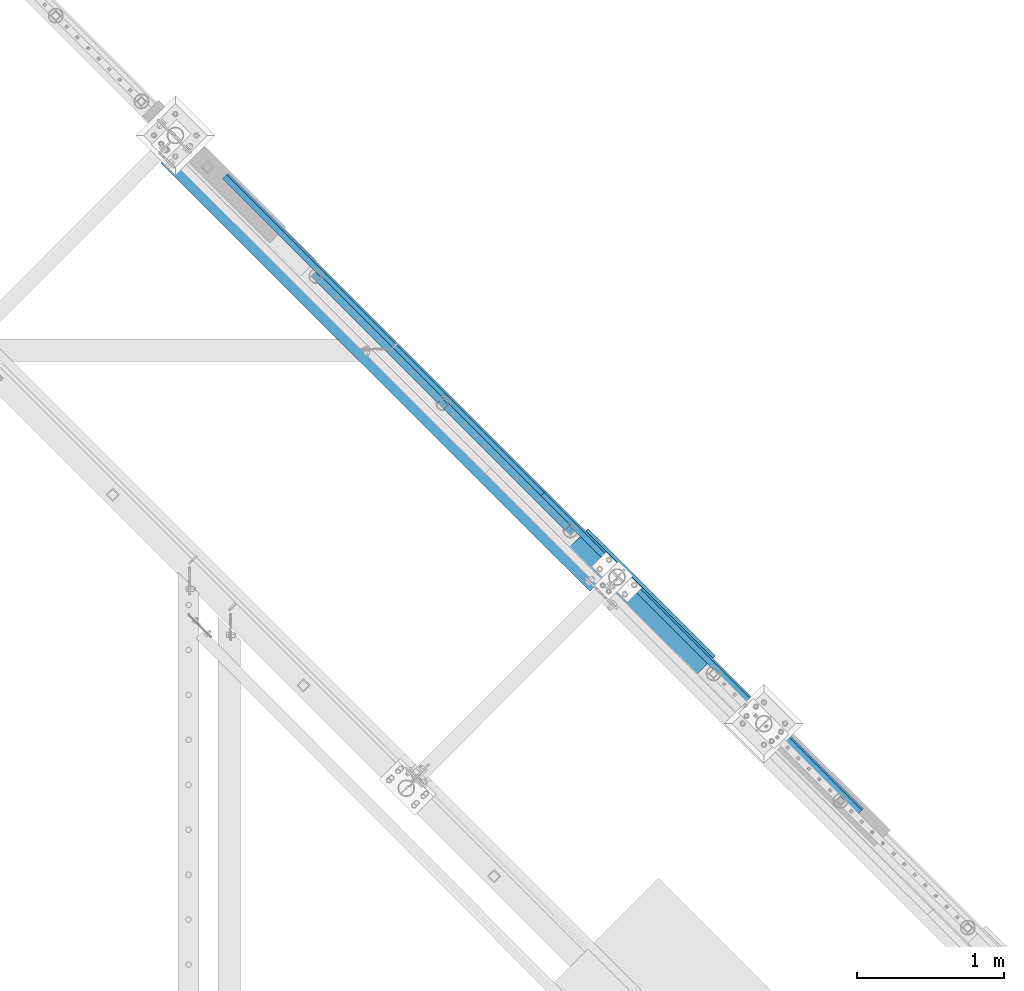
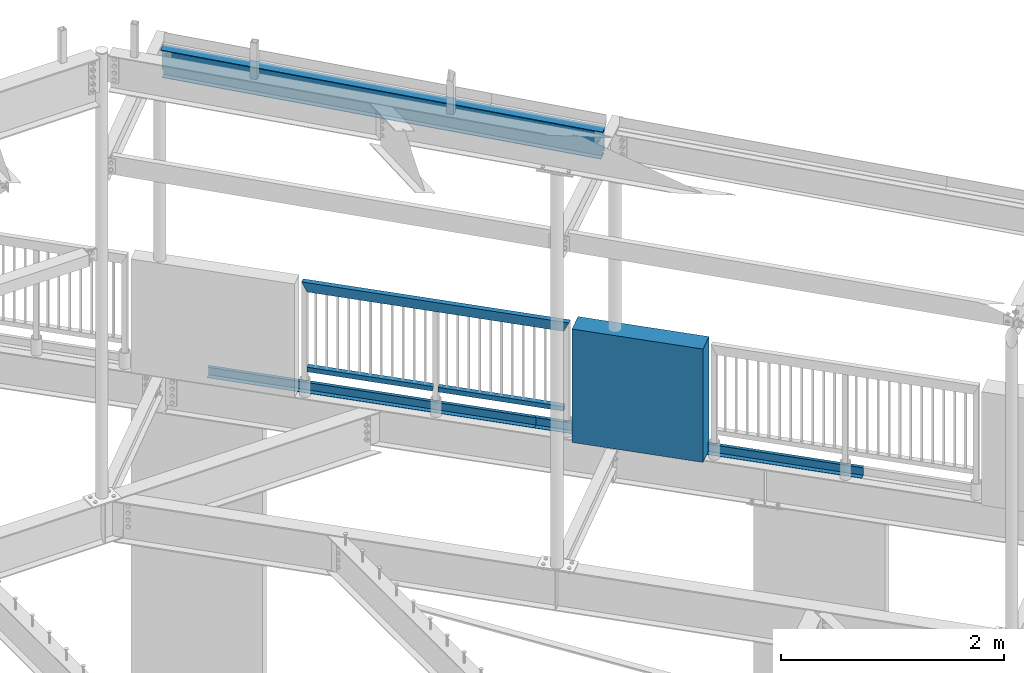
# One storey, part 375 of 975: 7 beams.
"""IFC2X3 building model written with IfcOpenShell, lengths in millimetres."""

from ifc_helpers import new_model, si_unit, frame, origin_with_axes, place, context, subcontext, project, spatial, faceted_brep, material, type_object, element, save


model = new_model("IFC2X3")

# Units and contexts
model_context = context("Model", 3, precision=1e-05, world=origin_with_axes())
body_context = subcontext(model_context, "Body", "Model", "MODEL_VIEW")
ifc_project = project(units=[si_unit("LENGTHUNIT", "METRE", prefix="MILLI"), si_unit("AREAUNIT", "SQUARE_METRE"), si_unit("VOLUMEUNIT", "CUBIC_METRE"), si_unit("MASSUNIT", "GRAM", prefix="KILO"), si_unit("TIMEUNIT", "SECOND"), si_unit("PLANEANGLEUNIT", "RADIAN"), si_unit("SOLIDANGLEUNIT", "STERADIAN"), si_unit("THERMODYNAMICTEMPERATUREUNIT", "DEGREE_CELSIUS"), si_unit("LUMINOUSINTENSITYUNIT", "LUMEN")], contexts=[model_context])

# Site, building, storey
site_placement = place(None, origin_with_axes())
site = spatial("IfcSite", under=ifc_project, at=site_placement, CompositionType="ELEMENT")
building_placement = place(site_placement, origin_with_axes())
building = spatial("IfcBuilding", under=site, at=building_placement, Name="Undefined", CompositionType="ELEMENT")
storey_placement = place(building_placement, origin_with_axes())
storey = spatial("IfcBuildingStorey", under=building, at=storey_placement, Name="Undefined", CompositionType="ELEMENT", Elevation=0.0)

# Beams
ifc_material_1 = material()
beam_type_1 = type_object("IfcBeamType", Name="HSS2X2X.188_TUBES", PredefinedType="NOTDEFINED")
beam_1_placement = place(storey_placement, frame((28372.9128589323, 20262.0233409861, 4229.10075294121), z_axis=(-0.707143406238003, -0.707070154237976, 0.0), x_axis=(-0.707070154237841, 0.707143406237869, -6.17000000467233e-07)))
element("IfcBeam", 1, at=beam_1_placement, inside=storey, type_object=beam_type_1, material=ifc_material_1, Name="HANDRAIL", ObjectType="HSS2X2X.188_TUBES", context=body_context, shape_type="Brep", body=[
    faceted_brep([(25.4008090784755, 20.6375000000126, -20.6375000000844), (25.4008182261714, -20.6374999999962, -20.6375000000407), (1193.80731114153, -20.6374999996497, -20.6375000016997), (1193.80733660824, 20.6375000003582, -20.6375000017506), (25.3986803055723, -20.6374999999962, 20.6375000000189), (1193.80517322093, -20.6374999996497, 20.63749999836), (25.3986711578782, 20.6375000000116, 20.6374999999753), (1193.80519868763, 20.6375000003572, 20.6374999983091), (25.4010547061143, 25.4000000000133, -25.400000000096), (25.3984234192258, 25.4000000000124, 25.3999999999724), (1193.80495494295, 25.400000000358, 25.3999999983134), (1193.80758622984, 25.400000000358, -25.4000000017622), (25.3984346779298, -25.3999999999969, 25.4000000000306), (1193.80492359932, -25.3999999996513, 25.3999999983716), (25.4010659648184, -25.3999999999969, -25.4000000000451), (1193.80755488621, -25.3999999996513, -25.400000001704)], [[[0, 1, 2, 3]], [[1, 4, 5, 2]], [[4, 6, 7, 5]], [[6, 0, 3, 7]], [[8, 9, 10, 11]], [[9, 12, 13, 10]], [[12, 14, 15, 13]], [[14, 8, 11, 15]], [[13, 15, 11, 10], [5, 7, 3, 2]], [[14, 12, 9, 8], [6, 4, 1, 0]]]),
])
beam_2_placement = place(storey_placement, frame((29234.9758876676, 19399.8710032537, 4229.10009527429), z_axis=(-0.707143406238003, -0.707070154237976, 0.0), x_axis=(-0.707070154237873, 0.7071434062379, 5.39000000270782e-07)))
element("IfcBeam", 2, at=beam_2_placement, inside=storey, type_object=beam_type_1, material=ifc_material_1, Name="HANDRAIL", ObjectType="HSS2X2X.188_TUBES", context=body_context, shape_type="Brep", body=[
    faceted_brep([(25.3959352503016, 20.6374999999971, -20.6375000000698), (25.395957497507, -20.637500000008, -20.6375000000553), (1193.80522150229, -20.6375000002545, -20.6375000017215), (1193.80516464068, 20.6374999997506, -20.637500001736), (25.3984002056568, -20.637500000008, 20.6374999999971), (1193.80308358158, -20.6375000002545, 20.6374999983382), (25.3983779584496, 20.637499999998, 20.6374999999898), (1193.80302671998, 20.6374999997506, 20.6374999983236), (25.3956508323763, 25.3999999999978, -25.4000000000815), (25.3986572424046, 25.3999999999978, 25.3999999999942), (1193.80277347587, 25.3999999997513, 25.399999998328), (1193.80540476288, 25.3999999997513, -25.4000000017404), (25.398684623583, -25.4000000000096, 25.4000000000087), (1193.80284345937, -25.4000000002561, 25.3999999983498), (25.3956782135529, -25.4000000000096, -25.4000000000597), (1193.8054747464, -25.400000000257, -25.4000000017259)], [[[0, 1, 2, 3]], [[1, 4, 5, 2]], [[4, 6, 7, 5]], [[6, 0, 3, 7]], [[8, 9, 10, 11]], [[9, 12, 13, 10]], [[12, 14, 15, 13]], [[14, 8, 11, 15]], [[13, 15, 11, 10], [5, 7, 3, 2]], [[14, 12, 9, 8], [6, 4, 1, 0]]]),
])
beam_type_2 = type_object("IfcBeamType", Name="HSS2X4X.188_TUBES", PredefinedType="NOTDEFINED")
beam_3_placement = place(storey_placement, frame((29234.9811726812, 19399.8762674095, 5130.80000000666), z_axis=(0.0, 0.0, 1.0), x_axis=(-0.70707231784675, 0.707141242846735, 0.0)))
element("IfcBeam", 3, at=beam_3_placement, inside=storey, type_object=beam_type_2, material=ifc_material_1, Name="GUARDRAIL", ObjectType="HSS2X4X.188_TUBES", context=body_context, shape_type="Brep", body=[
    faceted_brep([(23.0198915490837, 20.6374999999994, -46.0375000000031), (23.0198915283145, -20.6374999999966, -46.0375000000085), (2415.39077695601, -20.6374999954423, -46.0375000000004), (2415.39077695595, 20.63750000453, -46.0375000000004), (-23.0198845522937, -20.6374999999985, 46.0375000000058), (2461.43052065577, -20.637499995355, 46.0375000000004), (-23.0198845315244, 20.6374999999973, 46.0375000000113), (2461.43052065571, 20.6375000046173, 46.0375000000004), (25.4012592797953, 25.399999999999, -50.8000000000029), (-25.4012522574303, 25.3999999999967, 50.800000000012), (2463.81188670914, 25.4000000046217, 50.8000000000002), (2413.00941090251, 25.4000000045271, -50.8000000000002), (-25.401252282998, -25.3999999999983, 50.8000000000056), (2463.81188670921, -25.3999999953448, 50.8000000000002), (25.401259254224, -25.399999999996, -50.8000000000102), (2413.00941090258, -25.3999999954467, -50.8000000000002)], [[[0, 1, 2, 3]], [[1, 4, 5, 2]], [[4, 6, 7, 5]], [[6, 0, 3, 7]], [[8, 9, 10, 11]], [[9, 12, 13, 10]], [[12, 14, 15, 13]], [[14, 8, 11, 15]], [[13, 15, 11, 10], [5, 7, 3, 2]], [[14, 12, 9, 8], [6, 4, 1, 0]]]),
])
ifc_material_2 = material(Name="STEEL/A36")
beam_type_3 = type_object("IfcBeamType", PredefinedType="NOTDEFINED")
for number, where, z_axis, x_axis, name in (
    (4, (30107.8979694165, 18553.7318571938, 3938.58749694824), (0.707106781186513, -0.707106781186582, 3.1377567211166e-14), (0.707106781186548, 0.707106781186548, 0.0), "DECK_EDGE"),
    (5, (27952.6682824165, 20708.9615441938, 3938.58749694824), (0.707106781186513, -0.707106781186582, 3.1377567211166e-14), (0.707106781186548, 0.707106781186548, 0.0), "DECK_EDGE"),
):
    element("IfcBeam", number, at=place(storey_placement, frame(where, z_axis=z_axis, x_axis=x_axis)), inside=storey, type_object=beam_type_3, material=ifc_material_2, Name=name, context=body_context, shape_type="Brep", body=[
        faceted_brep([(1.03318598121405e-09, -1.58750000000009, -1524.00000000109), (-1.04046193882823e-09, -1.58750000000009, 1524.0000000011), (-1.04046193882823e-09, 1.58750000000009, 1524.0000000011), (1.03318598121405e-09, 1.58750000000009, -1524.00000000109), (47.6250001214066, 1.58750000000009, 1524.00000000113), (47.6250001235167, 1.58750000000009, -1524.00000000107), (50.8000001235196, -1.58750000000009, -1524.00000000106), (50.8000001214168, -1.58750000000009, 1524.00000000113), (47.6250001214503, 96.837499999901, 1524.00000000113), (47.625000123473, 96.8374999999951, -1524.00000000106), (50.8000001234759, 104.502628762961, -1524.00000000106), (50.8000001214605, 104.502628762867, 1524.00000000113), (38.6447461584321, 87.8572448731024, 1524.00000000113), (38.6447461604548, 87.8572448731024, -1524.00000000107), (36.3996819826862, 90.102308757891, 1524.00000000112), (36.3996819847016, 90.102308757891, -1524.00000000107)], [[[0, 1, 2, 3]], [[3, 2, 4, 5]], [[1, 0, 6, 7]], [[5, 4, 8, 9]], [[7, 6, 10, 11]], [[9, 8, 12, 13]], [[8, 4, 2, 1, 7, 11, 14, 12]], [[11, 10, 15, 14]], [[10, 6, 0, 3, 5, 9, 13, 15]], [[14, 15, 13, 12]]]),
    ])
ifc_material_3 = material(Name="CONCRETE/5000")
beam_type_4 = type_object("IfcBeamType", PredefinedType="NOTDEFINED")
beam_4_placement = place(storey_placement, frame((29282.9818692538, 19340.1196380567, 4559.3), z_axis=(0.0, 0.0, 1.0), x_axis=(0.707901544041155, -0.706311124041062, 0.0)))
element("IfcBeam", 6, at=beam_4_placement, inside=storey, type_object=beam_type_4, material=ifc_material_3, Name="LOW WALL", context=body_context, shape_type="Brep", body=[
    faceted_brep([(8.00355337560177e-11, 101.599999999831, -622.3), (8.00355337560177e-11, 101.599999999831, 622.3), (1219.20000000123, 101.599999998936, 622.3), (1219.20000000123, 101.599999998936, -622.3), (-7.27595761418343e-11, -101.599999999831, 622.3), (1219.20000000109, -101.600000000741, 622.3), (-7.27595761418343e-11, -101.599999999831, -622.3), (1219.20000000109, -101.600000000741, -622.3)], [[[0, 1, 2, 3]], [[1, 4, 5, 2]], [[4, 6, 7, 5]], [[6, 0, 3, 7]], [[5, 7, 3, 2]], [[6, 4, 1, 0]]]),
])
ifc_material_4 = material(Name="STEEL/A992")
beam_type_5 = type_object("IfcBeamType", Name="W12X14", PredefinedType="NOTDEFINED")
beam_5_placement = place(storey_placement, frame((26445.7189759491, 21973.2099400824, 7469.30209524686), z_axis=(-0.0275909098487173, 0.0275294238490569, -0.999240147570272), x_axis=(0.707357212670032, -0.705780872372475, -0.0389760680011505)))
element("IfcBeam", 7, at=beam_5_placement, inside=storey, type_object=beam_type_5, material=ifc_material_4, Name="BEAM", ObjectType="W12X14", context=body_context, shape_type="Brep", body=[
    faceted_brep([(4171.50424218042, -50.7999999924577, 150.812500000372), (4171.25628915001, -50.7999999924577, 144.462500000373), (4171.31001030482, -2.38124999245338, 144.46250000036), (4169.47310849961, -2.38124999246793, 97.4200160173805), (4169.47838451184, 2.38125000752916, 97.4198102228038), (4171.31529435283, 2.38125000754371, 144.462500000359), (4171.36901550764, 50.8000000075554, 144.462500000345), (4171.61696853806, 50.8000000075554, 150.812500000346), (4169.86129050471, -2.38124999246793, 94.9729665448131), (4169.86656651693, 2.38125000752916, 94.9727607502373), (4171.15636985333, -2.38124999246793, 92.8607383581211), (4171.16164586555, 2.38125000753644, 92.8605325635444), (4173.16118241644, -2.38124999246065, 91.4048991135105), (4173.16645842866, 2.38125000753644, 91.4046933189329), (4175.57051359598, -2.38124999246065, 90.827087181613), (4175.5757896082, 2.38125000754371, 90.8268813870363), (4184.55333280499, -2.38124999243882, 90.4763299449633), (4184.55265159303, 2.38125000755826, 90.4763567654973), (85.3496929344533, -50.7999999998065, 150.812500000005), (85.4624191070129, 50.8000000002066, 150.812499999979), (85.2147333913945, 50.8000000001921, 144.462499999979), (85.1610123247838, 2.381250000195, 144.462499999992), (83.3697785218724, 2.38125000018044, 98.5400509752562), (83.3645025096653, -2.38124999981665, 98.5402567698329), (85.1557282854487, -2.38124999980209, 144.462499999993), (85.1020072188403, -50.7999999998137, 144.462500000006), (82.7920673541835, 2.38125000018044, 96.1306973253868), (82.7867913419764, -2.38124999982392, 96.1309031199635), (81.3363115306342, 2.38125000017317, 94.1258252029374), (81.3310355184271, -2.38124999982392, 94.126030997515), (79.2241366788976, 2.38125000017317, 92.8306582143423), (79.2188606666905, -2.3812499998312, 92.830864008919), (76.7771022732345, 2.38125000016589, 92.4423737928955), (76.7718262610274, -2.3812499998312, 92.4425795874713), (67.6386991871573, 2.38125000015134, 92.7988229122548), (67.6386558410527, -2.38124999984575, 92.7988246034229), (58.3841731157449, 2.38125000006403, -144.462499999981), (58.3846144718168, 50.8000000000757, -144.462499999993), (58.1369287561997, 50.8000000000684, -150.812499999994), (58.1360026319844, -50.7999999999374, -150.812499999967), (58.3836883475997, -50.7999999999302, -144.462499999967), (58.3841297036752, -2.38124999993306, -144.462499999981), (4175.38871472335, 2.38125000747823, -144.462499999612), (4175.38177843254, 50.8000000074826, -144.462499999625), (4175.13409271582, 50.8000000074826, -150.812499999624), (4175.14864755556, -50.7999999925305, -150.812499999597), (4175.39633327228, -50.7999999925232, -144.462499999599), (4175.38939698146, -2.38124999251886, -144.462499999611)], [[[0, 1, 2, 3, 4, 5, 6, 7]], [[8, 9, 4, 3]], [[10, 11, 9, 8]], [[12, 13, 11, 10]], [[14, 15, 13, 12]], [[16, 17, 15, 14]], [[18, 19, 20, 21, 22, 23, 24, 25]], [[23, 22, 26, 27]], [[27, 26, 28, 29]], [[29, 28, 30, 31]], [[31, 30, 32, 33]], [[33, 32, 34, 35]], [[36, 37, 38, 39, 40, 41, 35, 34]], [[37, 36, 42, 43]], [[38, 37, 43, 44]], [[39, 38, 44, 45]], [[40, 39, 45, 46]], [[41, 40, 46, 47]], [[12, 10, 8, 3, 2, 24, 23, 27, 29, 31, 33, 35, 41, 47, 16, 14]], [[25, 24, 2, 1]], [[18, 25, 1, 0]], [[19, 18, 0, 7]], [[20, 19, 7, 6]], [[21, 20, 6, 5]], [[42, 36, 34, 32, 30, 28, 26, 22, 21, 5, 4, 9, 11, 13, 15, 17]], [[47, 46, 45, 44, 43, 42, 17, 16]]]),
])

save(model, "model.ifc")
